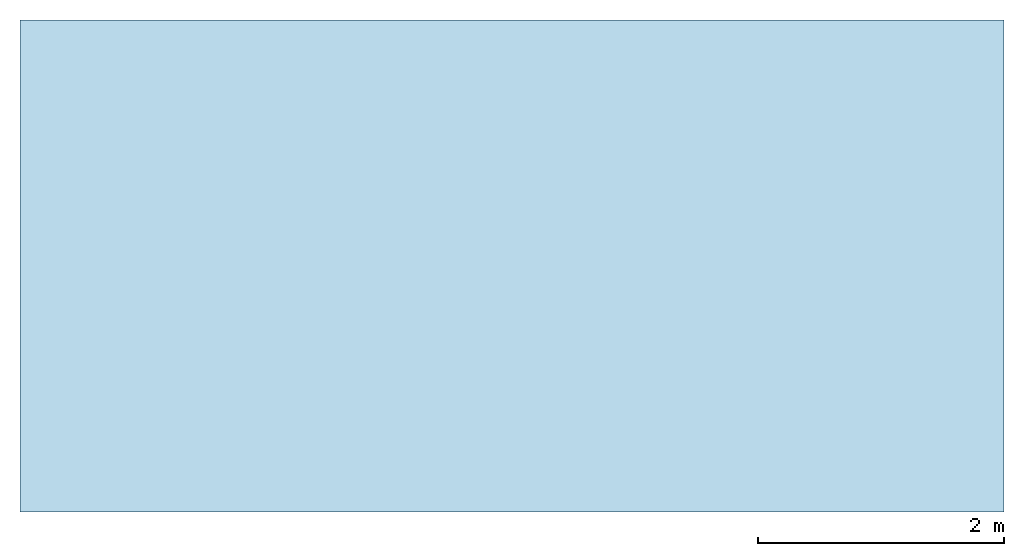
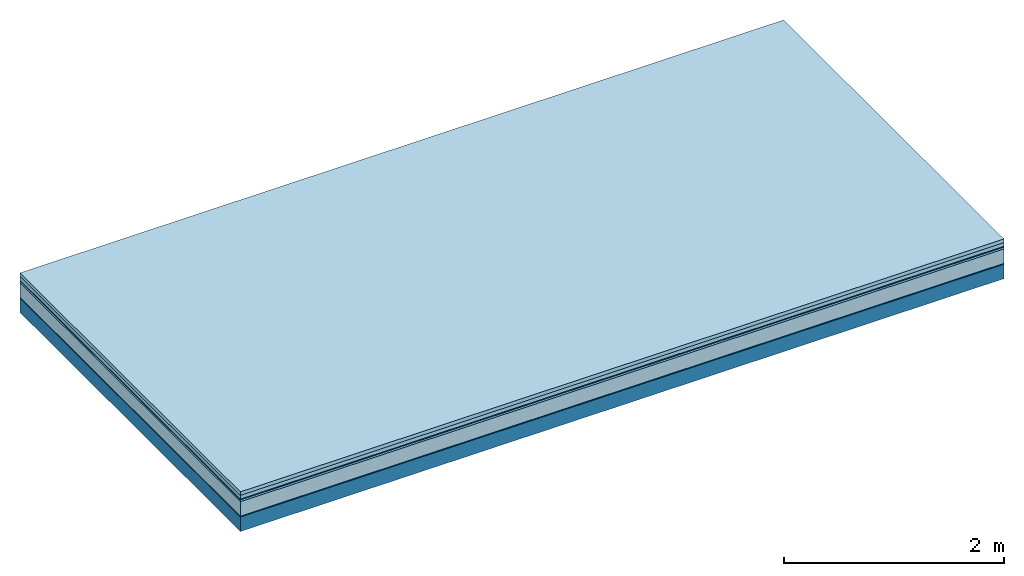
# One storey: 6 plates, 1 member, 1 element without a shape of its own.
"""IFC4 building model written with IfcOpenShell, lengths in metres."""

import ifcopenshell
import ifcopenshell.guid

model = None  # the IFC model being written
_history = None  # IfcOwnerHistory: only IFC2X3 demands one
_inside = {}  # id of a spatial element -> (the spatial element, [elements in it])
_under = {}  # id of a project, library or spatial element -> (it, [spatial elements below it])
_declared = {}  # id of a project -> (the project, [libraries it declares])
_typed = {}  # id of a type object -> (the type object, [elements of that type])
_made_of = {}  # id of a material, layer set ... -> (it, [elements and type objects made of it])


def new_model(schema):
    """Start an empty IFC model of exactly this schema.

    Asked for "IFC4X3", IfcOpenShell would pick the latest addendum, in which some entities
    have other attributes; the version numbers below select the first issue.
    IFC2X3 requires an IfcOwnerHistory on every rooted entity: one is made here for all.
    """
    global model, _history
    if schema == "IFC4X3":
        model = ifcopenshell.file(schema_version=(4, 3, 0, 0))
    else:
        model = ifcopenshell.file(schema=schema)
    _inside.clear()
    _under.clear()
    _declared.clear()
    _typed.clear()
    _made_of.clear()
    _history = None
    if model.schema == "IFC2X3":
        org = make("IfcOrganization", Name="unknown")
        user = make(
            "IfcPersonAndOrganization",
            ThePerson=make("IfcPerson", FamilyName="unknown"),
            TheOrganization=org,
        )
        app = make(
            "IfcApplication",
            ApplicationDeveloper=org,
            Version="unknown",
            ApplicationFullName="unknown",
            ApplicationIdentifier="unknown",
        )
        _history = make(
            "IfcOwnerHistory",
            OwningUser=user,
            OwningApplication=app,
            ChangeAction="ADDED",
            CreationDate=0,
        )
    return model


def make(cls, **values):
    """One entity of the class cls with the attributes given. An attribute that is None is left unset."""
    return model.create_entity(
        cls, **{name: value for name, value in values.items() if value is not None}
    )


def rooted(cls, **values):
    """An entity with a GlobalId (a new one), such as an element, a storey or a relation."""
    return make(cls, GlobalId=ifcopenshell.guid.new(), OwnerHistory=_history, **values)


def si_unit(unit_type, name, prefix=None):
    """IfcSIUnit, for example si_unit("LENGTHUNIT", "METRE", prefix="MILLI")."""
    return make("IfcSIUnit", UnitType=unit_type, Prefix=prefix, Name=name)


def derived_unit(unit_type, elements):
    """IfcDerivedUnit: a product of units, each with its exponent."""
    return make(
        "IfcDerivedUnit",
        Elements=[
            make("IfcDerivedUnitElement", Unit=unit, Exponent=power)
            for unit, power in elements
        ],
        UnitType=unit_type,
    )


def assignment(units):
    """IfcUnitAssignment: the units of a project."""
    return None if units is None else make("IfcUnitAssignment", Units=units)


def point(xyz):
    """IfcCartesianPoint."""
    return None if xyz is None else make("IfcCartesianPoint", Coordinates=xyz)


def direction(xyz):
    """IfcDirection."""
    return None if xyz is None else make("IfcDirection", DirectionRatios=xyz)


def frame(location, z_axis=None, x_axis=None):
    """IfcAxis2Placement3D, a coordinate frame: its origin and axes. An axis left out is left unset."""
    return make(
        "IfcAxis2Placement3D",
        Location=point(location),
        Axis=direction(z_axis),
        RefDirection=direction(x_axis),
    )


def frame_2d(location, x_axis=None):
    """IfcAxis2Placement2D, a coordinate frame in the plane: its origin and x axis."""
    return make(
        "IfcAxis2Placement2D", Location=point(location), RefDirection=direction(x_axis)
    )


def origin():
    """The frame at (0, 0, 0) with its axes left unset."""
    return frame((0.0, 0.0, 0.0))


def origin_with_axes():
    """The frame at (0, 0, 0) with the z axis (0, 0, 1) and the x axis (1, 0, 0) written out."""
    return frame((0.0, 0.0, 0.0), z_axis=(0.0, 0.0, 1.0), x_axis=(1.0, 0.0, 0.0))


def place(relative_to, where):
    """IfcLocalPlacement: puts the frame where relative to a parent placement (None: the world)."""
    return make(
        "IfcLocalPlacement", PlacementRelTo=relative_to, RelativePlacement=where
    )


def context(
    kind, dimensions, precision=None, world=None, true_north=None, identifier=None
):
    """IfcGeometricRepresentationContext, for example the 3D "Model" context."""
    return make(
        "IfcGeometricRepresentationContext",
        ContextIdentifier=identifier,
        ContextType=kind,
        CoordinateSpaceDimension=dimensions,
        Precision=precision,
        WorldCoordinateSystem=world,
        TrueNorth=true_north,
    )


def project(units=None, contexts=None):
    """IfcProject with its units and contexts."""
    return rooted(
        "IfcProject",
        Name="project",
        RepresentationContexts=contexts,
        UnitsInContext=assignment(units),
    )


def spatial(cls, under=None, at=None, **own):
    """A site, building, storey or space (cls), placed at a placement, below another one or the project."""
    s = rooted(cls, ObjectPlacement=at, **own)
    if under is not None:
        _under.setdefault(under.id(), (under, []))[1].append(s)
    return s


def profile(cls, at=None, kind="AREA", **sizes):
    """A parametric profile (cls). Its sizes go by their IFC names, for example OverallWidth=200.0."""
    return make(cls, ProfileType=kind, Position=at, **sizes)


def rectangle(**sizes):
    """IfcRectangleProfileDef."""
    return profile("IfcRectangleProfileDef", **sizes)


def extrude(swept, where, along, depth):
    """IfcExtrudedAreaSolid: the profile swept, set in the frame where, extruded along a direction by depth."""
    return make(
        "IfcExtrudedAreaSolid",
        SweptArea=swept,
        Position=where,
        ExtrudedDirection=direction(along),
        Depth=depth,
    )


def shape(context_of_items, identifier, shape_type, items):
    """IfcShapeRepresentation: the items that make up one representation, for example the "Body"."""
    return make(
        "IfcShapeRepresentation",
        ContextOfItems=context_of_items,
        RepresentationIdentifier=identifier,
        RepresentationType=shape_type,
        Items=items,
    )


def material(Name=None, Category=None):
    """IfcMaterial."""
    return make("IfcMaterial", Name=Name, Category=Category)


def layer(
    of_material, thickness, ventilated=None, Name=None, Category=None, Priority=None
):
    """IfcMaterialLayer: one layer of a wall or slab, of a material (None: an air gap)."""
    return make(
        "IfcMaterialLayer",
        Material=of_material,
        LayerThickness=thickness,
        IsVentilated=ventilated,
        Name=Name,
        Category=Category,
        Priority=Priority,
    )


def layer_set(layers, Name=None):
    """IfcMaterialLayerSet."""
    return make("IfcMaterialLayerSet", MaterialLayers=layers, LayerSetName=Name)


def made_of(thing, what):
    """Note that an element or type object is made of a material, layer set ...; save() writes the relation."""
    if what is not None:
        _made_of.setdefault(what.id(), (what, []))[1].append(thing)
    return thing


def type_object(cls, material=None, **own):
    """A type object (cls), such as IfcWallType, which elements share."""
    return made_of(rooted(cls, **own), material)


def element(
    cls,
    number,
    at=None,
    inside=None,
    cuts=None,
    type_object=None,
    material=None,
    context=None,
    identifier="Body",
    shape_type=None,
    held_by="IfcProductDefinitionShape",
    body=None,
    shapes=None,
    **own,
):
    """One element of the class cls, such as IfcWall. Its Tag is "e" and its number.

    at: its placement. inside: the storey or other place that contains it. cuts: it is an
    opening in that element (IfcRelVoidsElement). A single representation is given by context,
    identifier, shape_type and body (its items); several are given by shapes. held_by: the class
    of the entity that holds the representations. save() writes the other relations.
    """
    e = rooted(cls, Tag="e%d" % number, ObjectPlacement=at, **own)
    if body is not None:
        shapes = [shape(context, identifier, shape_type, body)]
    if shapes is not None:
        e.Representation = make(held_by, Representations=shapes)
    if inside is not None:
        _inside.setdefault(inside.id(), (inside, []))[1].append(e)
    if cuts is not None:
        rooted(
            "IfcRelVoidsElement", RelatingBuildingElement=cuts, RelatedOpeningElement=e
        )
    if type_object is not None:
        _typed.setdefault(type_object.id(), (type_object, []))[1].append(e)
    return made_of(e, material)


def aggregate(whole, parts):
    """IfcRelAggregates: a whole, such as a stair, and the parts it consists of."""
    return rooted("IfcRelAggregates", RelatingObject=whole, RelatedObjects=parts)


def save(model, path):
    """Write the relations noted so far, then the file.

    IfcRelAggregates (storeys below a building ...), IfcRelContainedInSpatialStructure (elements
    in a storey), IfcRelDefinesByType, IfcRelAssociatesMaterial and IfcRelDeclares: one each for
    every whole, place, type object, material and project.
    """
    for whole, parts in _under.values():
        aggregate(whole, parts)
    for where, things in _inside.values():
        rooted(
            "IfcRelContainedInSpatialStructure",
            RelatedElements=things,
            RelatingStructure=where,
        )
    for kind, things in _typed.values():
        rooted("IfcRelDefinesByType", RelatedObjects=things, RelatingType=kind)
    for what, things in _made_of.values():
        rooted("IfcRelAssociatesMaterial", RelatedObjects=things, RelatingMaterial=what)
    for by, libraries in _declared.values():
        rooted("IfcRelDeclares", RelatingContext=by, RelatedDefinitions=libraries)
    model.write(path)


model = new_model("IFC4")

# Units and contexts
plan_context = context("Plan", 3, precision=1e-05, world=origin(), true_north=direction((0.0, 1.0)))
model_context = context("Model", 3, precision=1e-05, world=origin(), true_north=direction((0.0, 1.0)))
ifc_project = project(units=[si_unit("LENGTHUNIT", "METRE"), derived_unit("SOUNDPRESSUREUNIT", [(si_unit("PRESSUREUNIT", "PASCAL", prefix="MICRO"), 0)]), si_unit("ENERGYUNIT", "JOULE", prefix="MEGA"), si_unit("MASSUNIT", "GRAM", prefix="KILO"), derived_unit("THERMALTRANSMITTANCEUNIT", [(si_unit("POWERUNIT", "WATT"), 1), (si_unit("AREAUNIT", "SQUARE_METRE"), -1), (si_unit("THERMODYNAMICTEMPERATUREUNIT", "KELVIN"), -1)]), derived_unit("AREADENSITYUNIT", [(si_unit("MASSUNIT", "GRAM", prefix="KILO"), 1), (si_unit("AREAUNIT", "SQUARE_METRE"), -1)]), derived_unit("USERDEFINED", [(si_unit("ENERGYUNIT", "JOULE", prefix="MEGA"), 1), (si_unit("AREAUNIT", "SQUARE_METRE"), -1)])], contexts=[plan_context, model_context])

# Site, building, storey
site = spatial("IfcSite", under=ifc_project)
building_placement = place(None, origin())
building = spatial("IfcBuilding", under=site, at=building_placement)
storey_placement = place(building_placement, origin())
storey = spatial("IfcBuildingStorey", under=building, at=storey_placement)

# Slab, member, plates
ifc_material_1 = material(Name="Garden plates", Category="02.007")
ifc_layer_1 = layer(ifc_material_1, 0.04, Name="Use and protection layer 3")
ifc_material_2 = material(Name="Gravel 8-16mm", Category="03.011")
ifc_layer_2 = layer(ifc_material_2, 0.04, Name="Use and protection layer 2")
ifc_material_3 = material(Name="Protective layer", Category="09.007")
ifc_layer_3 = layer(ifc_material_3, 0.01, Name="Use and protection layer 1")
ifc_material_4 = material(Name="Bituminous", Category="09.003")
ifc_layer_4 = layer(ifc_material_4, 0.02, Name="Seal")
ifc_material_5 = material(Name="Mineral wool", Category="10.008")
ifc_layer_5 = layer(ifc_material_5, 0.16, Name="Exterior insulation layer 1")
ifc_material_6 = material(Name="Vapor-permeable barrier", Category="09.006")
ifc_layer_6 = layer(ifc_material_6, 0.01, Name="layer / temporary roof")
ifc_material_7 = material(Name="no composite action")
ifc_layer_7 = layer(ifc_material_7, 0.0, Name="Bond")
ifc_layer_8 = layer(None, 0.16, Name="Support")
ifc_layer_set = layer_set([ifc_layer_1, ifc_layer_2, ifc_layer_3, ifc_layer_4, ifc_layer_5, ifc_layer_6, ifc_layer_7, ifc_layer_8])
slab_type = type_object("IfcSlabType", Name="F0048", PredefinedType="NOTDEFINED", material=ifc_layer_set)
slab_placement = place(None, frame((0.0, 0.0, 0.0), z_axis=(0.0, 0.0, -1.0), x_axis=(1.0, 0.0, 0.0)))
slab = element("IfcSlab", 1, at=slab_placement, inside=storey, type_object=slab_type, material=ifc_layer_set, Name="Slab #1")
ifc_material_8 = material(Name="Solid timber panel")
member_placement = place(slab_placement, origin())
member = element("IfcMember", 2, at=member_placement, material=ifc_material_8, Name="Support", context=plan_context, shape_type="SweptSolid", body=[
    extrude(rectangle(XDim=1.0, YDim=0.16, at=frame_2d((0.5, 0.08), x_axis=(1.0, 0.0))), frame((0.0, 4.0, 0.28), z_axis=(0.0, -1.0, 0.0), x_axis=(1.0, 0.0, 0.0)), (0.0, 0.0, 1.0), 4.0),
    extrude(rectangle(XDim=1.0, YDim=0.16, at=frame_2d((0.5, 0.08), x_axis=(1.0, 0.0))), frame((1.0, 4.0, 0.28), z_axis=(0.0, -1.0, 0.0), x_axis=(1.0, 0.0, 0.0)), (0.0, 0.0, 1.0), 4.0),
    extrude(rectangle(XDim=1.0, YDim=0.16, at=frame_2d((0.5, 0.08), x_axis=(1.0, 0.0))), frame((2.0, 4.0, 0.28), z_axis=(0.0, -1.0, 0.0), x_axis=(1.0, 0.0, 0.0)), (0.0, 0.0, 1.0), 4.0),
    extrude(rectangle(XDim=1.0, YDim=0.16, at=frame_2d((0.5, 0.08), x_axis=(1.0, 0.0))), frame((3.0, 4.0, 0.28), z_axis=(0.0, -1.0, 0.0), x_axis=(1.0, 0.0, 0.0)), (0.0, 0.0, 1.0), 4.0),
    extrude(rectangle(XDim=1.0, YDim=0.16, at=frame_2d((0.5, 0.08), x_axis=(1.0, 0.0))), frame((4.0, 4.0, 0.28), z_axis=(0.0, -1.0, 0.0), x_axis=(1.0, 0.0, 0.0)), (0.0, 0.0, 1.0), 4.0),
    extrude(rectangle(XDim=1.0, YDim=0.16, at=frame_2d((0.5, 0.08), x_axis=(1.0, 0.0))), frame((5.0, 4.0, 0.28), z_axis=(0.0, -1.0, 0.0), x_axis=(1.0, 0.0, 0.0)), (0.0, 0.0, 1.0), 4.0),
    extrude(rectangle(XDim=1.0, YDim=0.16, at=frame_2d((0.5, 0.08), x_axis=(1.0, 0.0))), frame((6.0, 4.0, 0.28), z_axis=(0.0, -1.0, 0.0), x_axis=(1.0, 0.0, 0.0)), (0.0, 0.0, 1.0), 4.0),
    extrude(rectangle(XDim=1.0, YDim=0.16, at=frame_2d((0.5, 0.08), x_axis=(1.0, 0.0))), frame((7.0, 4.0, 0.28), z_axis=(0.0, -1.0, 0.0), x_axis=(1.0, 0.0, 0.0)), (0.0, 0.0, 1.0), 4.0),
])
plate_1_placement = place(slab_placement, origin())
plate_1 = element("IfcPlate", 3, at=plate_1_placement, material=ifc_material_1, Name="Use and protection layer 3", context=plan_context, shape_type="SweptSolid", body=[
    extrude(rectangle(XDim=8.0, YDim=4.0, at=frame_2d((4.0, 2.0), x_axis=(1.0, 0.0))), origin_with_axes(), (0.0, 0.0, 1.0), 0.04),
])
plate_2_placement = place(slab_placement, origin())
plate_2 = element("IfcPlate", 4, at=plate_2_placement, material=ifc_material_2, Name="Use and protection layer 2", context=plan_context, shape_type="SweptSolid", body=[
    extrude(rectangle(XDim=8.0, YDim=4.0, at=frame_2d((4.0, 2.0), x_axis=(1.0, 0.0))), frame((0.0, 0.0, 0.04), z_axis=(0.0, 0.0, 1.0), x_axis=(1.0, 0.0, 0.0)), (0.0, 0.0, 1.0), 0.04),
])
plate_3_placement = place(slab_placement, origin())
plate_3 = element("IfcPlate", 5, at=plate_3_placement, material=ifc_material_3, Name="Use and protection layer 1", context=plan_context, shape_type="SweptSolid", body=[
    extrude(rectangle(XDim=8.0, YDim=4.0, at=frame_2d((4.0, 2.0), x_axis=(1.0, 0.0))), frame((0.0, 0.0, 0.08), z_axis=(0.0, 0.0, 1.0), x_axis=(1.0, 0.0, 0.0)), (0.0, 0.0, 1.0), 0.01),
])
plate_4_placement = place(slab_placement, origin())
plate_4 = element("IfcPlate", 6, at=plate_4_placement, material=ifc_material_4, Name="Seal", context=plan_context, shape_type="SweptSolid", body=[
    extrude(rectangle(XDim=8.0, YDim=4.0, at=frame_2d((4.0, 2.0), x_axis=(1.0, 0.0))), frame((0.0, 0.0, 0.09), z_axis=(0.0, 0.0, 1.0), x_axis=(1.0, 0.0, 0.0)), (0.0, 0.0, 1.0), 0.02),
])
plate_5_placement = place(slab_placement, origin())
plate_5 = element("IfcPlate", 7, at=plate_5_placement, material=ifc_material_5, Name="Exterior insulation layer 1", context=plan_context, shape_type="SweptSolid", body=[
    extrude(rectangle(XDim=8.0, YDim=4.0, at=frame_2d((4.0, 2.0), x_axis=(1.0, 0.0))), frame((0.0, 0.0, 0.11), z_axis=(0.0, 0.0, 1.0), x_axis=(1.0, 0.0, 0.0)), (0.0, 0.0, 1.0), 0.16),
])
plate_6_placement = place(slab_placement, origin())
plate_6 = element("IfcPlate", 8, at=plate_6_placement, material=ifc_material_6, Name="layer / temporary roof", context=plan_context, shape_type="SweptSolid", body=[
    extrude(rectangle(XDim=8.0, YDim=4.0, at=frame_2d((4.0, 2.0), x_axis=(1.0, 0.0))), frame((0.0, 0.0, 0.27), z_axis=(0.0, 0.0, 1.0), x_axis=(1.0, 0.0, 0.0)), (0.0, 0.0, 1.0), 0.01),
])
aggregate(slab, [plate_1, plate_2, plate_3, plate_4, plate_5, plate_6, member])

save(model, "model.ifc")
